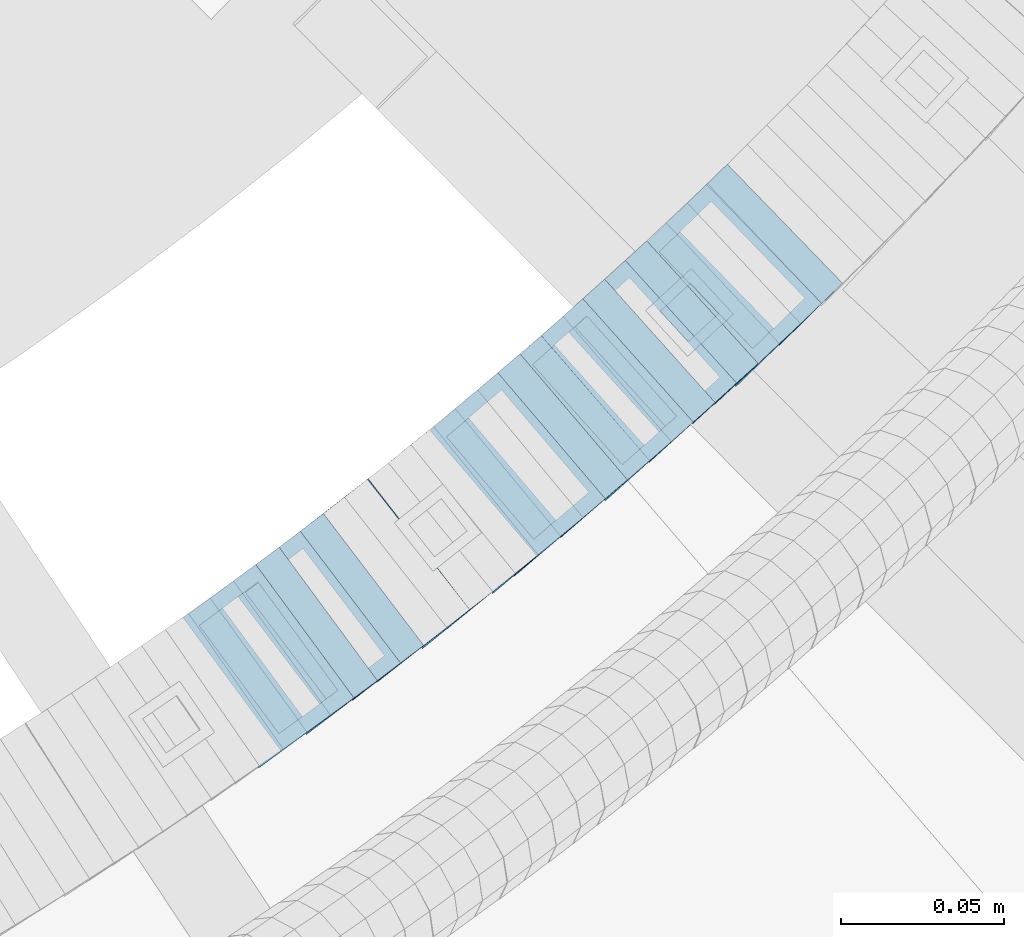
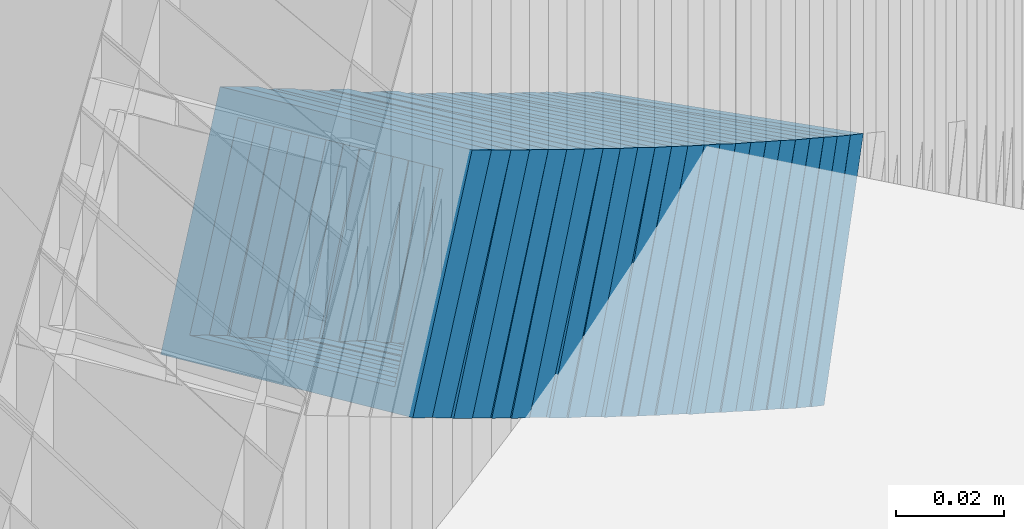
# One storey, part 737 of 975: 24 members.
"""IFC2X3 building model written with IfcOpenShell, lengths in millimetres."""

from ifc_helpers import new_model, si_unit, frame, origin_with_axes, place, context, subcontext, project, spatial, faceted_brep, material, type_object, element, save


model = new_model("IFC2X3")

# Units and contexts
model_context = context("Model", 3, precision=1e-05, world=origin_with_axes())
body_context = subcontext(model_context, "Body", "Model", "MODEL_VIEW")
ifc_project = project(units=[si_unit("LENGTHUNIT", "METRE", prefix="MILLI"), si_unit("AREAUNIT", "SQUARE_METRE"), si_unit("VOLUMEUNIT", "CUBIC_METRE"), si_unit("MASSUNIT", "GRAM", prefix="KILO"), si_unit("TIMEUNIT", "SECOND"), si_unit("PLANEANGLEUNIT", "RADIAN"), si_unit("SOLIDANGLEUNIT", "STERADIAN"), si_unit("THERMODYNAMICTEMPERATUREUNIT", "DEGREE_CELSIUS"), si_unit("LUMINOUSINTENSITYUNIT", "LUMEN")], contexts=[model_context])

# Site, building, storey
site_placement = place(None, origin_with_axes())
site = spatial("IfcSite", under=ifc_project, at=site_placement, CompositionType="ELEMENT")
building_placement = place(site_placement, origin_with_axes())
building = spatial("IfcBuilding", under=site, at=building_placement, Name="Undefined", CompositionType="ELEMENT")
storey_placement = place(building_placement, origin_with_axes())
storey = spatial("IfcBuildingStorey", under=building, at=storey_placement, Name="Undefined", CompositionType="ELEMENT", Elevation=0.0)

# Members
ifc_material = material()
member_type = type_object("IfcMemberType", Name="HSS2X2X.188_TUBES", PredefinedType="NOTDEFINED")
member_1_placement = place(storey_placement, frame((35551.9109170345, 2270.43465632298, 2714.48259582463), z_axis=(0.592817428282397, -0.80533688399616, -1.4644820112153e-10), x_axis=(-0.679063997791954, -0.49986655384685, 0.53759233183527)))
element("IfcMember", 1, at=member_1_placement, inside=storey, type_object=member_type, material=ifc_material, Name="WALL", ObjectType="HSS2X2X.188_TUBES", context=body_context, shape_type="Brep", body=[
    faceted_brep([(0.0, 20.6374999999753, -20.6375000000298), (0.0, -20.6375000000153, -20.6375000000153), (10.6004716875832, -20.6375000000153, -20.6375000000553), (10.6004716875814, 20.6374999999898, -20.6375000000444), (0.0, -20.6374999999825, 20.6375000000335), (10.6004716876068, -20.6375000000044, 20.6374999999862), (0.0, 20.6375000000116, 20.6375000000189), (10.6004716876032, 20.6374999999989, 20.6374999999971), (0.0, 25.3999999999724, -25.4000000000342), (0.0, 25.400000000016, 25.4000000000196), (10.600471687605, 25.4000000000015, 25.4000000000051), (10.6004716875814, 25.3999999999869, -25.4000000000487), (0.0, -25.399999999976, 25.4000000000378), (10.6004716876068, -25.4000000000015, 25.3999999999905), (0.0, -25.400000000016, -25.4000000000196), (10.6004716875814, -25.4000000000178, -25.4000000000669)], [[[0, 1, 2, 3]], [[1, 4, 5, 2]], [[4, 6, 7, 5]], [[6, 0, 3, 7]], [[8, 9, 10, 11]], [[9, 12, 13, 10]], [[12, 14, 15, 13]], [[14, 8, 11, 15]], [[13, 15, 11, 10], [5, 7, 3, 2]], [[14, 12, 9, 8], [6, 4, 1, 0]]]),
])
member_2_placement = place(storey_placement, frame((35558.9747885788, 2275.63445065421, 2708.79130711657), z_axis=(0.592817428282397, -0.80533688399616, -1.4644820112153e-10), x_axis=(-0.675617177995566, -0.497329311996747, 0.544247171996465)))
element("IfcMember", 2, at=member_2_placement, inside=storey, type_object=member_type, material=ifc_material, Name="WALL", ObjectType="HSS2X2X.188_TUBES", context=body_context, shape_type="Brep", body=[
    faceted_brep([(0.0, 20.6374999999753, -20.6375000000298), (0.0, -20.6375000000153, -20.6375000000153), (10.6625512894789, -20.6374999999625, -20.6374999999389), (10.6625512893879, 20.6374999999789, -20.6375000000371), (0.0, -20.6374999999825, 20.6375000000335), (10.6625512894352, -20.6374999999989, 20.6375000000153), (0.0, 20.6375000000116, 20.6375000000189), (10.6625512893443, 20.6374999999443, 20.6374999999134), (0.0, 25.3999999999724, -25.4000000000342), (0.0, 25.400000000016, 25.4000000000196), (10.6625512893297, 25.3999999999342, 25.3999999998996), (10.6625512893916, 25.399999999976, -25.4000000000415), (0.0, -25.399999999976, 25.4000000000378), (10.6625512894389, -25.399999999996, 25.400000000016), (0.0, -25.400000000016, -25.4000000000196), (10.6625512894971, -25.3999999999523, -25.3999999999214)], [[[0, 1, 2, 3]], [[1, 4, 5, 2]], [[4, 6, 7, 5]], [[6, 0, 3, 7]], [[8, 9, 10, 11]], [[9, 12, 13, 10]], [[12, 14, 15, 13]], [[14, 8, 11, 15]], [[13, 15, 11, 10], [5, 7, 3, 2]], [[14, 12, 9, 8], [6, 4, 1, 0]]]),
])
for number, where, z_axis, x_axis, name in (
    (3, (35566.002931472, 2280.71149481148, 2702.99658430275), (0.605367471185716, -0.795946119300931, 2.19515641219914e-11), (-0.670707309990836, -0.510115418993075, 0.538455163992673), "WALL"),
    (4, (35573.102931472, 2286.1114948115, 2697.29658430275), (0.605367471185716, -0.795946119300931, 2.19515641219914e-11), (-0.670707309990836, -0.510115418993075, 0.538455163992673), "WALL"),
):
    element("IfcMember", number, at=place(storey_placement, frame(where, z_axis=z_axis, x_axis=x_axis)), inside=storey, type_object=member_type, material=ifc_material, Name=name, ObjectType="HSS2X2X.188_TUBES", context=body_context, shape_type="Brep", body=[
        faceted_brep([(0.0, 20.6374999999753, -20.6375000000298), (0.0, -20.6375000000153, -20.6375000000153), (10.5948100501191, -20.6375000000335, -20.6375000000844), (10.5948100501555, 20.6374999999971, -20.6375000000116), (0.0, -20.6374999999825, 20.6375000000335), (10.5948100501446, -20.6375000000098, 20.6374999999571), (0.0, 20.6375000000116, 20.6375000000189), (10.5948100501828, 20.6375000000189, 20.6375000000298), (0.0, 25.3999999999724, -25.4000000000342), (0.0, 25.400000000016, 25.4000000000196), (10.5948100501919, 25.4000000000251, 25.4000000000451), (10.5948100501591, 25.3999999999978, -25.4000000000051), (0.0, -25.399999999976, 25.4000000000378), (10.5948100501482, -25.4000000000106, 25.3999999999578), (0.0, -25.400000000016, -25.4000000000196), (10.5948100501118, -25.4000000000378, -25.400000000096)], [[[0, 1, 2, 3]], [[1, 4, 5, 2]], [[4, 6, 7, 5]], [[6, 0, 3, 7]], [[8, 9, 10, 11]], [[9, 12, 13, 10]], [[12, 14, 15, 13]], [[14, 8, 11, 15]], [[13, 15, 11, 10], [5, 7, 3, 2]], [[14, 12, 9, 8], [6, 4, 1, 0]]]),
    ])
member_3_placement = place(storey_placement, frame((35580.016817613, 2291.31526045801, 2691.56268787828), z_axis=(0.612397742071008, -0.790549812160076, 2.70556483883411e-11), x_axis=(-0.664102681131868, -0.514445739102183, 0.54250641510776)))
element("IfcMember", 5, at=member_3_placement, inside=storey, type_object=member_type, material=ifc_material, Name="WALL", ObjectType="HSS2X2X.188_TUBES", context=body_context, shape_type="Brep", body=[
    faceted_brep([(0.0, 20.6374999999753, -20.6375000000298), (0.0, -20.6375000000153, -20.6375000000153), (10.6906501205649, -20.6374999999844, -20.637499999968), (10.690650120574, 20.6375000000098, -20.6374999999716), (0.0, -20.6374999999825, 20.6375000000335), (10.6906501205467, -20.6374999999844, 20.637500000008), (0.0, 20.6375000000116, 20.6375000000189), (10.6906501205558, 20.637500000008, 20.6375000000007), (0.0, 25.3999999999724, -25.4000000000342), (0.0, 25.400000000016, 25.4000000000196), (10.6906501205522, 25.4000000000087, 25.3999999999978), (10.6906501205813, 25.4000000000124, -25.3999999999651), (0.0, -25.399999999976, 25.4000000000378), (10.6906501205431, -25.3999999999833, 25.4000000000051), (0.0, -25.400000000016, -25.4000000000196), (10.6906501205704, -25.3999999999833, -25.3999999999614)], [[[0, 1, 2, 3]], [[1, 4, 5, 2]], [[4, 6, 7, 5]], [[6, 0, 3, 7]], [[8, 9, 10, 11]], [[9, 12, 13, 10]], [[12, 14, 15, 13]], [[14, 8, 11, 15]], [[13, 15, 11, 10], [5, 7, 3, 2]], [[14, 12, 9, 8], [6, 4, 1, 0]]]),
])
member_4_placement = place(storey_placement, frame((35587.0028866664, 2296.68452711863, 2685.80910192297), z_axis=(0.617821551956281, -0.786318338803269, -5.58129613636994e-11), x_axis=(-0.662206907099039, -0.520305427077868, 0.539225625080672)))
element("IfcMember", 6, at=member_4_placement, inside=storey, type_object=member_type, material=ifc_material, Name="WALL", ObjectType="HSS2X2X.188_TUBES", context=body_context, shape_type="Brep", body=[
    faceted_brep([(0.0, 20.6374999999753, -20.6375000000298), (0.0, -20.6375000000153, -20.6375000000153), (10.5744976239494, -20.6375000000207, -20.6375000000335), (10.5744976239657, 20.6375000000098, -20.637500000008), (0.0, -20.6374999999825, 20.6375000000335), (10.5744976239639, -20.6375000000244, 20.6374999999753), (0.0, 20.6375000000116, 20.6375000000189), (10.5744976239803, 20.6374999999989, 20.6374999999935), (0.0, 25.3999999999724, -25.4000000000342), (0.0, 25.400000000016, 25.4000000000196), (10.5744976239857, 25.4000000000051, 25.4000000000015), (10.5744976239675, 25.4000000000124, -25.4000000000051), (0.0, -25.399999999976, 25.4000000000378), (10.5744976239639, -25.4000000000287, 25.3999999999724), (0.0, -25.400000000016, -25.4000000000196), (10.5744976239494, -25.4000000000215, -25.4000000000378)], [[[0, 1, 2, 3]], [[1, 4, 5, 2]], [[4, 6, 7, 5]], [[6, 0, 3, 7]], [[8, 9, 10, 11]], [[9, 12, 13, 10]], [[12, 14, 15, 13]], [[14, 8, 11, 15]], [[13, 15, 11, 10], [5, 7, 3, 2]], [[14, 12, 9, 8], [6, 4, 1, 0]]]),
])
member_5_placement = place(storey_placement, frame((35594.2503706419, 2302.41871702971, 2680.0545311128), z_axis=(0.612397742071008, -0.790549812160076, 2.70556483883411e-11), x_axis=(-0.667468953075577, -0.51705341405853, 0.535855357060665)))
element("IfcMember", 7, at=member_5_placement, inside=storey, type_object=member_type, material=ifc_material, Name="WALL", ObjectType="HSS2X2X.188_TUBES", context=body_context, shape_type="Brep", body=[
    faceted_brep([(0.0, 20.6374999999753, -20.6375000000298), (0.0, -20.6375000000153, -20.6375000000153), (10.6395488625676, -20.6374999999771, -20.6374999999716), (10.6395488625531, 20.6374999999916, -20.6375000000189), (0.0, -20.6374999999825, 20.6375000000335), (10.6395488625731, -20.6374999999844, 20.6375000000153), (0.0, 20.6375000000116, 20.6375000000189), (10.6395488625585, 20.6374999999825, 20.637499999968), (0.0, 25.3999999999724, -25.4000000000342), (0.0, 25.400000000016, 25.4000000000196), (10.6395488625567, 25.3999999999778, 25.3999999999614), (10.6395488625494, 25.3999999999887, -25.4000000000233), (0.0, -25.399999999976, 25.4000000000378), (10.6395488625749, -25.3999999999851, 25.400000000016), (0.0, -25.400000000016, -25.4000000000196), (10.6395488625658, -25.399999999976, -25.3999999999687)], [[[0, 1, 2, 3]], [[1, 4, 5, 2]], [[4, 6, 7, 5]], [[6, 0, 3, 7]], [[8, 9, 10, 11]], [[9, 12, 13, 10]], [[12, 14, 15, 13]], [[14, 8, 11, 15]], [[13, 15, 11, 10], [5, 7, 3, 2]], [[14, 12, 9, 8], [6, 4, 1, 0]]]),
])
member_6_placement = place(storey_placement, frame((35600.679623241, 2307.24753393565, 2674.4295682067), z_axis=(0.630168888016676, -0.776458094539445, 2.13421117223333e-10), x_axis=(-0.65022043110368, -0.527715132084138, 0.546562101087119)))
element("IfcMember", 8, at=member_6_placement, inside=storey, type_object=member_type, material=ifc_material, Name="WALL", ObjectType="HSS2X2X.188_TUBES", context=body_context, shape_type="Brep", body=[
    faceted_brep([(0.0, 20.6374999999753, -20.6375000000298), (0.0, -20.6375000000153, -20.6375000000153), (10.6061303028146, -20.6374999999571, -20.6374999999643), (10.6061303027491, 20.6374999999971, -20.6375000000007), (0.0, -20.6374999999825, 20.6375000000335), (10.6061303027855, -20.6374999999825, 20.6375000000116), (0.0, 20.6375000000116, 20.6375000000189), (10.6061303027236, 20.637499999968, 20.6374999999716), (0.0, 25.3999999999724, -25.4000000000342), (0.0, 25.400000000016, 25.4000000000196), (10.6061303027163, 25.3999999999651, 25.3999999999651), (10.6061303027454, 25.3999999999942, -25.4000000000051), (0.0, -25.399999999976, 25.4000000000378), (10.6061303027891, -25.3999999999796, 25.4000000000124), (0.0, -25.400000000016, -25.4000000000196), (10.6061303028182, -25.3999999999505, -25.3999999999542)], [[[0, 1, 2, 3]], [[1, 4, 5, 2]], [[4, 6, 7, 5]], [[6, 0, 3, 7]], [[8, 9, 10, 11]], [[9, 12, 13, 10]], [[12, 14, 15, 13]], [[14, 8, 11, 15]], [[13, 15, 11, 10], [5, 7, 3, 2]], [[14, 12, 9, 8], [6, 4, 1, 0]]]),
])
member_7_placement = place(storey_placement, frame((35607.9112541427, 2313.10717802574, 2668.52310227178), z_axis=(0.631426343294012, -0.775435860013162, -1.38708401209442e-10), x_axis=(-0.65566758518045, -0.533900748146899, 0.533900748146899)))
element("IfcMember", 9, at=member_7_placement, inside=storey, type_object=member_type, material=ifc_material, Name="WALL", ObjectType="HSS2X2X.188_TUBES", context=body_context, shape_type="Brep", body=[
    faceted_brep([(0.0, 20.6374999999753, -20.6375000000298), (0.0, -20.6375000000153, -20.6375000000153), (10.6831643251735, -20.6375000000498, -20.6375000000953), (10.6831643252044, 20.637499999988, -20.6375000000226), (0.0, -20.6374999999825, 20.6375000000335), (10.6831643251935, -20.6375000000135, 20.637499999968), (0.0, 20.6375000000116, 20.6375000000189), (10.6831643252244, 20.6375000000226, 20.6375000000407), (0.0, 25.3999999999724, -25.4000000000342), (0.0, 25.400000000016, 25.4000000000196), (10.6831643252317, 25.4000000000306, 25.4000000000597), (10.6831643252044, 25.3999999999905, -25.4000000000196), (0.0, -25.399999999976, 25.4000000000378), (10.6831643251917, -25.400000000016, 25.3999999999614), (0.0, -25.400000000016, -25.4000000000196), (10.6831643251644, -25.400000000056, -25.4000000001179)], [[[0, 1, 2, 3]], [[1, 4, 5, 2]], [[4, 6, 7, 5]], [[6, 0, 3, 7]], [[8, 9, 10, 11]], [[9, 12, 13, 10]], [[12, 14, 15, 13]], [[14, 8, 11, 15]], [[13, 15, 11, 10], [5, 7, 3, 2]], [[14, 12, 9, 8], [6, 4, 1, 0]]]),
])
member_8_placement = place(storey_placement, frame((35614.579623241, 2318.54753393565, 2662.9295682067), z_axis=(0.630168888016676, -0.776458094539445, 2.13421117223333e-10), x_axis=(-0.65022043110368, -0.527715132084138, 0.546562101087119)))
element("IfcMember", 10, at=member_8_placement, inside=storey, type_object=member_type, material=ifc_material, Name="WALL", ObjectType="HSS2X2X.188_TUBES", context=body_context, shape_type="Brep", body=[
    faceted_brep([(0.0, 20.6374999999753, -20.6375000000298), (0.0, -20.6375000000153, -20.6375000000153), (10.6061303028146, -20.6374999999571, -20.6374999999643), (10.6061303027491, 20.6374999999971, -20.6375000000007), (0.0, -20.6374999999825, 20.6375000000335), (10.6061303027855, -20.6374999999825, 20.6375000000116), (0.0, 20.6375000000116, 20.6375000000189), (10.6061303027236, 20.637499999968, 20.6374999999716), (0.0, 25.3999999999724, -25.4000000000342), (0.0, 25.400000000016, 25.4000000000196), (10.6061303027163, 25.3999999999651, 25.3999999999651), (10.6061303027454, 25.3999999999942, -25.4000000000051), (0.0, -25.399999999976, 25.4000000000378), (10.6061303027891, -25.3999999999796, 25.4000000000124), (0.0, -25.400000000016, -25.4000000000196), (10.6061303028182, -25.3999999999505, -25.3999999999542)], [[[0, 1, 2, 3]], [[1, 4, 5, 2]], [[4, 6, 7, 5]], [[6, 0, 3, 7]], [[8, 9, 10, 11]], [[9, 12, 13, 10]], [[12, 14, 15, 13]], [[14, 8, 11, 15]], [[13, 15, 11, 10], [5, 7, 3, 2]], [[14, 12, 9, 8], [6, 4, 1, 0]]]),
])
member_9_placement = place(storey_placement, frame((35621.5297774591, 2324.08217317924, 2657.03213827413), z_axis=(0.64345222746142, -0.765486270925179, 2.30264049605466e-10), x_axis=(-0.646982418110182, -0.54384029309259, 0.53446373709099)))
element("IfcMember", 11, at=member_9_placement, inside=storey, type_object=member_type, material=ifc_material, Name="WALL", ObjectType="HSS2X2X.188_TUBES", context=body_context, shape_type="Brep", body=[
    faceted_brep([(0.0, 20.6374999999753, -20.6375000000298), (0.0, -20.6375000000153, -20.6375000000153), (10.6625512894789, -20.6374999999625, -20.6374999999389), (10.6625512893879, 20.6374999999789, -20.6375000000371), (0.0, -20.6374999999825, 20.6375000000335), (10.6625512894352, -20.6374999999989, 20.6375000000153), (0.0, 20.6375000000116, 20.6375000000189), (10.6625512893443, 20.6374999999443, 20.6374999999134), (0.0, 25.3999999999724, -25.4000000000342), (0.0, 25.400000000016, 25.4000000000196), (10.6625512893297, 25.3999999999342, 25.3999999998996), (10.6625512893916, 25.399999999976, -25.4000000000415), (0.0, -25.399999999976, 25.4000000000378), (10.6625512894389, -25.399999999996, 25.400000000016), (0.0, -25.400000000016, -25.4000000000196), (10.6625512894971, -25.3999999999523, -25.3999999999214)], [[[0, 1, 2, 3]], [[1, 4, 5, 2]], [[4, 6, 7, 5]], [[6, 0, 3, 7]], [[8, 9, 10, 11]], [[9, 12, 13, 10]], [[12, 14, 15, 13]], [[14, 8, 11, 15]], [[13, 15, 11, 10], [5, 7, 3, 2]], [[14, 12, 9, 8], [6, 4, 1, 0]]]),
])
member_10_placement = place(storey_placement, frame((35628.0619945693, 2329.52617785358, 2651.39328222406), z_axis=(0.648946606019702, -0.760833952012862, -4.31282387580723e-12), x_axis=(-0.638223397472876, -0.544367015403294, 0.544367015403294)))
element("IfcMember", 12, at=member_10_placement, inside=storey, type_object=member_type, material=ifc_material, Name="WALL", ObjectType="HSS2X2X.188_TUBES", context=body_context, shape_type="Brep", body=[
    faceted_brep([(0.0, 20.6374999999753, -20.6375000000298), (0.0, -20.6375000000153, -20.6375000000153), (10.648004507897, -20.6374999999862, -20.637499999968), (10.6480045078188, 20.6374999999771, -20.6375000000808), (0.0, -20.6374999999825, 20.6375000000335), (10.6480045079406, -20.6374999999698, 20.6375000001062), (0.0, 20.6375000000116, 20.6375000000189), (10.6480045078679, 20.6374999999935, 20.6375000000007), (0.0, 25.3999999999724, -25.4000000000342), (0.0, 25.400000000016, 25.4000000000196), (10.6480045078661, 25.3999999999905, 25.4000000000015), (10.648004507806, 25.3999999999705, -25.4000000000997), (0.0, -25.399999999976, 25.4000000000378), (10.6480045079552, -25.3999999999633, 25.4000000001288), (0.0, -25.400000000016, -25.4000000000196), (10.6480045078988, -25.3999999999814, -25.3999999999651)], [[[0, 1, 2, 3]], [[1, 4, 5, 2]], [[4, 6, 7, 5]], [[6, 0, 3, 7]], [[8, 9, 10, 11]], [[9, 12, 13, 10]], [[12, 14, 15, 13]], [[14, 8, 11, 15]], [[13, 15, 11, 10], [5, 7, 3, 2]], [[14, 12, 9, 8], [6, 4, 1, 0]]]),
])
member_11_placement = place(storey_placement, frame((35634.9906054734, 2335.43587538938, 2645.58453276387), z_axis=(0.648946606019702, -0.760833952012862, -4.31282387580723e-12), x_axis=(-0.641480888746966, -0.547145463784153, 0.537711921787891)))
element("IfcMember", 13, at=member_11_placement, inside=storey, type_object=member_type, material=ifc_material, Name="WALL", ObjectType="HSS2X2X.188_TUBES", context=body_context, shape_type="Brep", body=[
    faceted_brep([(0.0, 20.6374999999753, -20.6375000000298), (0.0, -20.6375000000153, -20.6375000000153), (10.6004716875832, -20.6375000000153, -20.6375000000553), (10.6004716875814, 20.6374999999898, -20.6375000000444), (0.0, -20.6374999999825, 20.6375000000335), (10.6004716876068, -20.6375000000044, 20.6374999999862), (0.0, 20.6375000000116, 20.6375000000189), (10.6004716876032, 20.6374999999989, 20.6374999999971), (0.0, 25.3999999999724, -25.4000000000342), (0.0, 25.400000000016, 25.4000000000196), (10.600471687605, 25.4000000000015, 25.4000000000051), (10.6004716875814, 25.3999999999869, -25.4000000000487), (0.0, -25.399999999976, 25.4000000000378), (10.6004716876068, -25.4000000000015, 25.3999999999905), (0.0, -25.400000000016, -25.4000000000196), (10.6004716875814, -25.4000000000178, -25.4000000000669)], [[[0, 1, 2, 3]], [[1, 4, 5, 2]], [[4, 6, 7, 5]], [[6, 0, 3, 7]], [[8, 9, 10, 11]], [[9, 12, 13, 10]], [[12, 14, 15, 13]], [[14, 8, 11, 15]], [[13, 15, 11, 10], [5, 7, 3, 2]], [[14, 12, 9, 8], [6, 4, 1, 0]]]),
])
member_12_placement = place(storey_placement, frame((35641.7564402481, 2341.15461850356, 2639.83970037974), z_axis=(0.655353317111826, -0.755322467394242, 1.10103883343982e-10), x_axis=(-0.638167183753088, -0.553703879785835, 0.53493425679308)))
element("IfcMember", 14, at=member_12_placement, inside=storey, type_object=member_type, material=ifc_material, Name="WALL", ObjectType="HSS2X2X.188_TUBES", context=body_context, shape_type="Brep", body=[
    faceted_brep([(0.0, 20.6374999999753, -20.6375000000298), (0.0, -20.6375000000153, -20.6375000000153), (10.6625512894789, -20.6374999999625, -20.6374999999389), (10.6625512893879, 20.6374999999789, -20.6375000000371), (0.0, -20.6374999999825, 20.6375000000335), (10.6625512894352, -20.6374999999989, 20.6375000000153), (0.0, 20.6375000000116, 20.6375000000189), (10.6625512893443, 20.6374999999443, 20.6374999999134), (0.0, 25.3999999999724, -25.4000000000342), (0.0, 25.400000000016, 25.4000000000196), (10.6625512893297, 25.3999999999342, 25.3999999998996), (10.6625512893916, 25.399999999976, -25.4000000000415), (0.0, -25.399999999976, 25.4000000000378), (10.6625512894389, -25.399999999996, 25.400000000016), (0.0, -25.400000000016, -25.4000000000196), (10.6625512894971, -25.3999999999523, -25.3999999999214)], [[[0, 1, 2, 3]], [[1, 4, 5, 2]], [[4, 6, 7, 5]], [[6, 0, 3, 7]], [[8, 9, 10, 11]], [[9, 12, 13, 10]], [[12, 14, 15, 13]], [[14, 8, 11, 15]], [[13, 15, 11, 10], [5, 7, 3, 2]], [[14, 12, 9, 8], [6, 4, 1, 0]]]),
])
member_13_placement = place(storey_placement, frame((35648.2241883576, 2346.77385934597, 2634.24734681059), z_axis=(0.654500819759056, -0.756061291784418, 2.68819349003024e-11), x_axis=(-0.632610568111146, -0.54763302909617, 0.54763302909617)))
element("IfcMember", 15, at=member_13_placement, inside=storey, type_object=member_type, material=ifc_material, Name="WALL", ObjectType="HSS2X2X.188_TUBES", context=body_context, shape_type="Brep", body=[
    faceted_brep([(0.0, 20.6374999999753, -20.6375000000298), (0.0, -20.6375000000153, -20.6375000000153), (10.5948100501191, -20.6375000000335, -20.6375000000844), (10.5948100501555, 20.6374999999971, -20.6375000000116), (0.0, -20.6374999999825, 20.6375000000335), (10.5948100501446, -20.6375000000098, 20.6374999999571), (0.0, 20.6375000000116, 20.6375000000189), (10.5948100501828, 20.6375000000189, 20.6375000000298), (0.0, 25.3999999999724, -25.4000000000342), (0.0, 25.400000000016, 25.4000000000196), (10.5948100501919, 25.4000000000251, 25.4000000000451), (10.5948100501591, 25.3999999999978, -25.4000000000051), (0.0, -25.399999999976, 25.4000000000378), (10.5948100501482, -25.4000000000106, 25.3999999999578), (0.0, -25.400000000016, -25.4000000000196), (10.5948100501118, -25.4000000000378, -25.400000000096)], [[[0, 1, 2, 3]], [[1, 4, 5, 2]], [[4, 6, 7, 5]], [[6, 0, 3, 7]], [[8, 9, 10, 11]], [[9, 12, 13, 10]], [[12, 14, 15, 13]], [[14, 8, 11, 15]], [[13, 15, 11, 10], [5, 7, 3, 2]], [[14, 12, 9, 8], [6, 4, 1, 0]]]),
])
member_14_placement = place(storey_placement, frame((35654.9913601684, 2352.52490055984, 2628.34577120092), z_axis=(0.667119803196771, -0.744950446796766, -1.78824848262593e-10), x_axis=(-0.629225879194317, -0.563485862173961, 0.535311569165292)))
element("IfcMember", 16, at=member_14_placement, inside=storey, type_object=member_type, material=ifc_material, Name="WALL", ObjectType="HSS2X2X.188_TUBES", context=body_context, shape_type="Brep", body=[
    faceted_brep([(0.0, 20.6374999999753, -20.6375000000298), (0.0, -20.6375000000153, -20.6375000000153), (10.648004507897, -20.6374999999862, -20.637499999968), (10.6480045078188, 20.6374999999771, -20.6375000000808), (0.0, -20.6374999999825, 20.6375000000335), (10.6480045079406, -20.6374999999698, 20.6375000001062), (0.0, 20.6375000000116, 20.6375000000189), (10.6480045078679, 20.6374999999935, 20.6375000000007), (0.0, 25.3999999999724, -25.4000000000342), (0.0, 25.400000000016, 25.4000000000196), (10.6480045078661, 25.3999999999905, 25.4000000000015), (10.648004507806, 25.3999999999705, -25.4000000000997), (0.0, -25.399999999976, 25.4000000000378), (10.6480045079552, -25.3999999999633, 25.4000000001288), (0.0, -25.400000000016, -25.4000000000196), (10.6480045078988, -25.3999999999814, -25.3999999999651)], [[[0, 1, 2, 3]], [[1, 4, 5, 2]], [[4, 6, 7, 5]], [[6, 0, 3, 7]], [[8, 9, 10, 11]], [[9, 12, 13, 10]], [[12, 14, 15, 13]], [[14, 8, 11, 15]], [[13, 15, 11, 10], [5, 7, 3, 2]], [[14, 12, 9, 8], [6, 4, 1, 0]]]),
])
member_15_placement = place(storey_placement, frame((35661.5655336158, 2358.41222006503, 2622.65375430605), z_axis=(0.667119803196771, -0.744950446796766, -1.78824848262593e-10), x_axis=(-0.626058869184097, -0.560649733164906, 0.541961409159407)))
element("IfcMember", 17, at=member_15_placement, inside=storey, type_object=member_type, material=ifc_material, Name="WALL", ObjectType="HSS2X2X.188_TUBES", context=body_context, shape_type="Brep", body=[
    faceted_brep([(0.0, 20.6374999999753, -20.6375000000298), (0.0, -20.6375000000153, -20.6375000000153), (10.6985980389491, -20.6375000000317, -20.6375000000698), (10.6985980389982, 20.6375000000116, -20.6374999999643), (0.0, -20.6374999999825, 20.6375000000335), (10.6985980389818, -20.6374999999989, 20.6374999999789), (0.0, 20.6375000000116, 20.6375000000189), (10.6985980390309, 20.6375000000407, 20.6375000000808), (0.0, 25.3999999999724, -25.4000000000342), (0.0, 25.400000000016, 25.4000000000196), (10.6985980390382, 25.4000000000487, 25.4000000000997), (10.6985980390036, 25.4000000000142, -25.3999999999542), (0.0, -25.399999999976, 25.4000000000378), (10.6985980389763, -25.4000000000033, 25.3999999999724), (0.0, -25.400000000016, -25.4000000000196), (10.6985980389418, -25.400000000036, -25.4000000000851)], [[[0, 1, 2, 3]], [[1, 4, 5, 2]], [[4, 6, 7, 5]], [[6, 0, 3, 7]], [[8, 9, 10, 11]], [[9, 12, 13, 10]], [[12, 14, 15, 13]], [[14, 8, 11, 15]], [[13, 15, 11, 10], [5, 7, 3, 2]], [[14, 12, 9, 8], [6, 4, 1, 0]]]),
])
member_16_placement = place(storey_placement, frame((35668.1589060118, 2364.26801189506, 2616.89697428563), z_axis=(0.672672794095991, -0.739940073305327, 8.58585735841189e-11), x_axis=(-0.623502221313723, -0.56682020128522, 0.538479191270969)))
element("IfcMember", 18, at=member_16_placement, inside=storey, type_object=member_type, material=ifc_material, Name="WALL", ObjectType="HSS2X2X.188_TUBES", context=body_context, shape_type="Brep", body=[
    faceted_brep([(0.0, 20.6374999999753, -20.6375000000298), (0.0, -20.6375000000153, -20.6375000000153), (10.5948100501191, -20.6375000000335, -20.6375000000844), (10.5948100501555, 20.6374999999971, -20.6375000000116), (0.0, -20.6374999999825, 20.6375000000335), (10.5948100501446, -20.6375000000098, 20.6374999999571), (0.0, 20.6375000000116, 20.6375000000189), (10.5948100501828, 20.6375000000189, 20.6375000000298), (0.0, 25.3999999999724, -25.4000000000342), (0.0, 25.400000000016, 25.4000000000196), (10.5948100501919, 25.4000000000251, 25.4000000000451), (10.5948100501591, 25.3999999999978, -25.4000000000051), (0.0, -25.399999999976, 25.4000000000378), (10.5948100501482, -25.4000000000106, 25.3999999999578), (0.0, -25.400000000016, -25.4000000000196), (10.5948100501118, -25.4000000000378, -25.400000000096)], [[[0, 1, 2, 3]], [[1, 4, 5, 2]], [[4, 6, 7, 5]], [[6, 0, 3, 7]], [[8, 9, 10, 11]], [[9, 12, 13, 10]], [[12, 14, 15, 13]], [[14, 8, 11, 15]], [[13, 15, 11, 10], [5, 7, 3, 2]], [[14, 12, 9, 8], [6, 4, 1, 0]]]),
])
for number, where, z_axis, x_axis, name in (
    (19, (35674.6337967248, 2370.1542761796, 2611.20596859345), (0.672672794095991, -0.739940073305327, 8.58585735841189e-11), (-0.620327053965999, -0.563933684969047, 0.545135895970075), "WALL"),
    (20, (35681.3346354787, 2376.19341240115, 2605.35033670451), (0.678742108762795, -0.734376708367194, 2.68552412308054e-10), (-0.6201627217675, -0.573180696785174, 0.535595077799254), "WALL"),
):
    element("IfcMember", number, at=place(storey_placement, frame(where, z_axis=z_axis, x_axis=x_axis)), inside=storey, type_object=member_type, material=ifc_material, Name=name, ObjectType="HSS2X2X.188_TUBES", context=body_context, shape_type="Brep", body=[
        faceted_brep([(0.0, 20.6374999999753, -20.6375000000298), (0.0, -20.6375000000153, -20.6375000000153), (10.6395488625676, -20.6374999999771, -20.6374999999716), (10.6395488625531, 20.6374999999916, -20.6375000000189), (0.0, -20.6374999999825, 20.6375000000335), (10.6395488625731, -20.6374999999844, 20.6375000000153), (0.0, 20.6375000000116, 20.6375000000189), (10.6395488625585, 20.6374999999825, 20.637499999968), (0.0, 25.3999999999724, -25.4000000000342), (0.0, 25.400000000016, 25.4000000000196), (10.6395488625567, 25.3999999999778, 25.3999999999614), (10.6395488625494, 25.3999999999887, -25.4000000000233), (0.0, -25.399999999976, 25.4000000000378), (10.6395488625749, -25.3999999999851, 25.400000000016), (0.0, -25.400000000016, -25.4000000000196), (10.6395488625658, -25.399999999976, -25.3999999999687)], [[[0, 1, 2, 3]], [[1, 4, 5, 2]], [[4, 6, 7, 5]], [[6, 0, 3, 7]], [[8, 9, 10, 11]], [[9, 12, 13, 10]], [[12, 14, 15, 13]], [[14, 8, 11, 15]], [[13, 15, 11, 10], [5, 7, 3, 2]], [[14, 12, 9, 8], [6, 4, 1, 0]]]),
    ])
member_17_placement = place(storey_placement, frame((35687.7058309349, 2382.03148738003, 2599.70087833793), z_axis=(0.684314204029273, -0.729187266868932, -7.10006133886054e-11), x_axis=(-0.614329411220402, -0.576524524206858, 0.538719637193272)))
element("IfcMember", 21, at=member_17_placement, inside=storey, type_object=member_type, material=ifc_material, Name="WALL", ObjectType="HSS2X2X.188_TUBES", context=body_context, shape_type="Brep", body=[
    faceted_brep([(0.0, 20.6374999999753, -20.6375000000298), (0.0, -20.6375000000153, -20.6375000000153), (10.5806427026419, -20.6374999999607, -20.6374999999316), (10.5806427026473, 20.6375000000444, -20.6374999999207), (0.0, -20.6374999999825, 20.6375000000335), (10.5806427025509, -20.6375000000207, 20.6374999999643), (0.0, 20.6375000000116, 20.6375000000189), (10.5806427025545, 20.6374999999862, 20.6374999999716), (0.0, 25.3999999999724, -25.4000000000342), (0.0, 25.400000000016, 25.4000000000196), (10.5806427025436, 25.3999999999796, 25.3999999999614), (10.5806427026582, 25.4000000000542, -25.3999999999105), (0.0, -25.399999999976, 25.4000000000378), (10.5806427025418, -25.4000000000287, 25.3999999999542), (0.0, -25.400000000016, -25.4000000000196), (10.5806427026528, -25.3999999999542, -25.3999999999178)], [[[0, 1, 2, 3]], [[1, 4, 5, 2]], [[4, 6, 7, 5]], [[6, 0, 3, 7]], [[8, 9, 10, 11]], [[9, 12, 13, 10]], [[12, 14, 15, 13]], [[14, 8, 11, 15]], [[13, 15, 11, 10], [5, 7, 3, 2]], [[14, 12, 9, 8], [6, 4, 1, 0]]]),
])
member_18_placement = place(storey_placement, frame((35693.8399173614, 2387.67612056073, 2594.01234156434), z_axis=(0.695795215511426, -0.718240223094898, 2.71390035777586e-10), x_axis=(-0.601954824818967, -0.583143735824535, 0.54552155983588)))
element("IfcMember", 22, at=member_18_placement, inside=storey, type_object=member_type, material=ifc_material, Name="WALL", ObjectType="HSS2X2X.188_TUBES", context=body_context, shape_type="Brep", body=[
    faceted_brep([(0.0, 20.6374999999753, -20.6375000000298), (0.0, -20.6375000000153, -20.6375000000153), (10.6348483769107, -20.637499999988, -20.6374999999825), (10.6348483768415, 20.6374999999734, -20.6375000001026), (0.0, -20.6374999999825, 20.6375000000335), (10.6348483769852, -20.6374999999589, 20.6375000001462), (0.0, 20.6375000000116, 20.6375000000189), (10.6348483769161, 20.6375000000044, 20.6375000000226), (0.0, 25.3999999999724, -25.4000000000342), (0.0, 25.400000000016, 25.4000000000196), (10.6348483769179, 25.4000000000015, 25.4000000000233), (10.6348483768288, 25.3999999999669, -25.4000000001324), (0.0, -25.399999999976, 25.4000000000378), (10.6348483769998, -25.3999999999505, 25.4000000001688), (0.0, -25.400000000016, -25.4000000000196), (10.6348483769107, -25.3999999999887, -25.3999999999833)], [[[0, 1, 2, 3]], [[1, 4, 5, 2]], [[4, 6, 7, 5]], [[6, 0, 3, 7]], [[8, 9, 10, 11]], [[9, 12, 13, 10]], [[12, 14, 15, 13]], [[14, 8, 11, 15]], [[13, 15, 11, 10], [5, 7, 3, 2]], [[14, 12, 9, 8], [6, 4, 1, 0]]]),
])
member_19_placement = place(storey_placement, frame((35700.3613721409, 2393.99377987838, 2588.20322446153), z_axis=(0.695795215511426, -0.718240223094898, 2.71390035777586e-10), x_axis=(-0.605040347855636, -0.586132836860087, 0.538864059871391)))
element("IfcMember", 23, at=member_19_placement, inside=storey, type_object=member_type, material=ifc_material, Name="WALL", ObjectType="HSS2X2X.188_TUBES", context=body_context, shape_type="Brep", body=[
    faceted_brep([(0.0, 20.6374999999753, -20.6375000000298), (0.0, -20.6375000000153, -20.6375000000153), (10.5806427026419, -20.6374999999607, -20.6374999999316), (10.5806427026473, 20.6375000000444, -20.6374999999207), (0.0, -20.6374999999825, 20.6375000000335), (10.5806427025509, -20.6375000000207, 20.6374999999643), (0.0, 20.6375000000116, 20.6375000000189), (10.5806427025545, 20.6374999999862, 20.6374999999716), (0.0, 25.3999999999724, -25.4000000000342), (0.0, 25.400000000016, 25.4000000000196), (10.5806427025436, 25.3999999999796, 25.3999999999614), (10.5806427026582, 25.4000000000542, -25.3999999999105), (0.0, -25.399999999976, 25.4000000000378), (10.5806427025418, -25.4000000000287, 25.3999999999542), (0.0, -25.400000000016, -25.4000000000196), (10.5806427026528, -25.3999999999542, -25.3999999999178)], [[[0, 1, 2, 3]], [[1, 4, 5, 2]], [[4, 6, 7, 5]], [[6, 0, 3, 7]], [[8, 9, 10, 11]], [[9, 12, 13, 10]], [[12, 14, 15, 13]], [[14, 8, 11, 15]], [[13, 15, 11, 10], [5, 7, 3, 2]], [[14, 12, 9, 8], [6, 4, 1, 0]]]),
])
member_20_placement = place(storey_placement, frame((35706.7465456511, 2400.12672089944, 2582.45491286781), z_axis=(0.701517264451547, -0.712652459250944, 3.59814748662756e-10), x_axis=(-0.601688743935452, -0.592287356936542, 0.535879036942577)))
element("IfcMember", 24, at=member_20_placement, inside=storey, type_object=member_type, material=ifc_material, Name="WALL", ObjectType="HSS2X2X.188_TUBES", context=body_context, shape_type="Brep", body=[
    faceted_brep([(0.0, 20.6374999999753, -20.6375000000298), (0.0, -20.6375000000153, -20.6375000000153), (10.6395488625676, -20.6374999999771, -20.6374999999716), (10.6395488625531, 20.6374999999916, -20.6375000000189), (0.0, -20.6374999999825, 20.6375000000335), (10.6395488625731, -20.6374999999844, 20.6375000000153), (0.0, 20.6375000000116, 20.6375000000189), (10.6395488625585, 20.6374999999825, 20.637499999968), (0.0, 25.3999999999724, -25.4000000000342), (0.0, 25.400000000016, 25.4000000000196), (10.6395488625567, 25.3999999999778, 25.3999999999614), (10.6395488625494, 25.3999999999887, -25.4000000000233), (0.0, -25.399999999976, 25.4000000000378), (10.6395488625749, -25.3999999999851, 25.400000000016), (0.0, -25.400000000016, -25.4000000000196), (10.6395488625658, -25.399999999976, -25.3999999999687)], [[[0, 1, 2, 3]], [[1, 4, 5, 2]], [[4, 6, 7, 5]], [[6, 0, 3, 7]], [[8, 9, 10, 11]], [[9, 12, 13, 10]], [[12, 14, 15, 13]], [[14, 8, 11, 15]], [[13, 15, 11, 10], [5, 7, 3, 2]], [[14, 12, 9, 8], [6, 4, 1, 0]]]),
])

save(model, "model.ifc")
